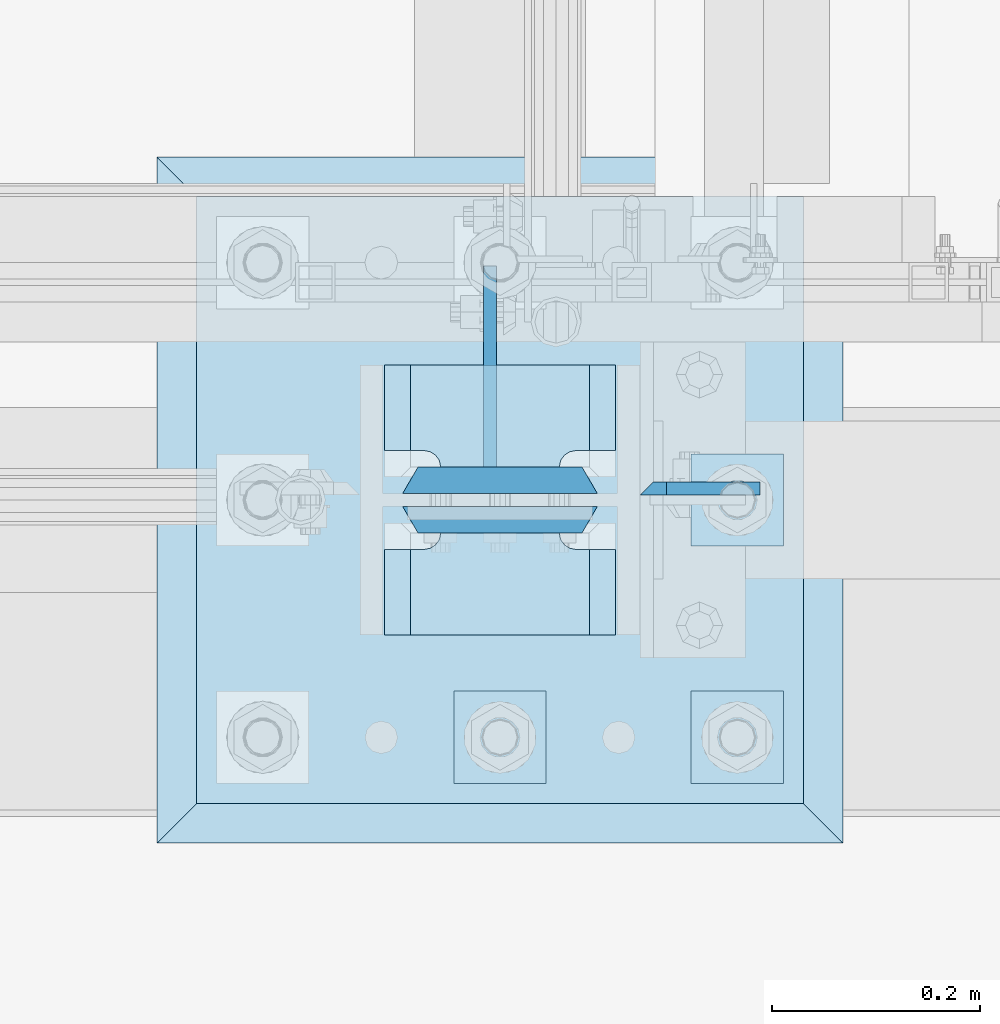
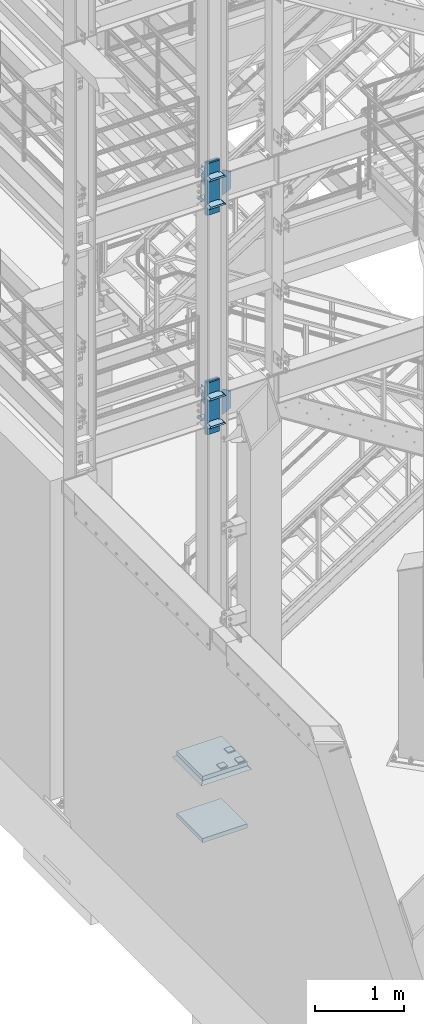
# One storey, part 1436 of 1876: 22 plates, 3 elements without a shape of their own.
"""IFC2X3 building model written with IfcOpenShell, lengths in millimetres."""

import ifcopenshell
import ifcopenshell.guid

model = None  # the IFC model being written
_history = None  # IfcOwnerHistory: only IFC2X3 demands one
_inside = {}  # id of a spatial element -> (the spatial element, [elements in it])
_under = {}  # id of a project, library or spatial element -> (it, [spatial elements below it])
_declared = {}  # id of a project -> (the project, [libraries it declares])
_typed = {}  # id of a type object -> (the type object, [elements of that type])
_made_of = {}  # id of a material, layer set ... -> (it, [elements and type objects made of it])


def new_model(schema):
    """Start an empty IFC model of exactly this schema.

    Asked for "IFC4X3", IfcOpenShell would pick the latest addendum, in which some entities
    have other attributes; the version numbers below select the first issue.
    IFC2X3 requires an IfcOwnerHistory on every rooted entity: one is made here for all.
    """
    global model, _history
    if schema == "IFC4X3":
        model = ifcopenshell.file(schema_version=(4, 3, 0, 0))
    else:
        model = ifcopenshell.file(schema=schema)
    _inside.clear()
    _under.clear()
    _declared.clear()
    _typed.clear()
    _made_of.clear()
    _history = None
    if model.schema == "IFC2X3":
        org = make("IfcOrganization", Name="unknown")
        user = make(
            "IfcPersonAndOrganization",
            ThePerson=make("IfcPerson", FamilyName="unknown"),
            TheOrganization=org,
        )
        app = make(
            "IfcApplication",
            ApplicationDeveloper=org,
            Version="unknown",
            ApplicationFullName="unknown",
            ApplicationIdentifier="unknown",
        )
        _history = make(
            "IfcOwnerHistory",
            OwningUser=user,
            OwningApplication=app,
            ChangeAction="ADDED",
            CreationDate=0,
        )
    return model


def make(cls, **values):
    """One entity of the class cls with the attributes given. An attribute that is None is left unset."""
    return model.create_entity(
        cls, **{name: value for name, value in values.items() if value is not None}
    )


def rooted(cls, **values):
    """An entity with a GlobalId (a new one), such as an element, a storey or a relation."""
    return make(cls, GlobalId=ifcopenshell.guid.new(), OwnerHistory=_history, **values)


def si_unit(unit_type, name, prefix=None):
    """IfcSIUnit, for example si_unit("LENGTHUNIT", "METRE", prefix="MILLI")."""
    return make("IfcSIUnit", UnitType=unit_type, Prefix=prefix, Name=name)


def assignment(units):
    """IfcUnitAssignment: the units of a project."""
    return None if units is None else make("IfcUnitAssignment", Units=units)


def point(xyz):
    """IfcCartesianPoint."""
    return None if xyz is None else make("IfcCartesianPoint", Coordinates=xyz)


def direction(xyz):
    """IfcDirection."""
    return None if xyz is None else make("IfcDirection", DirectionRatios=xyz)


def frame(location, z_axis=None, x_axis=None):
    """IfcAxis2Placement3D, a coordinate frame: its origin and axes. An axis left out is left unset."""
    return make(
        "IfcAxis2Placement3D",
        Location=point(location),
        Axis=direction(z_axis),
        RefDirection=direction(x_axis),
    )


def origin_with_axes():
    """The frame at (0, 0, 0) with the z axis (0, 0, 1) and the x axis (1, 0, 0) written out."""
    return frame((0.0, 0.0, 0.0), z_axis=(0.0, 0.0, 1.0), x_axis=(1.0, 0.0, 0.0))


def place(relative_to, where):
    """IfcLocalPlacement: puts the frame where relative to a parent placement (None: the world)."""
    return make(
        "IfcLocalPlacement", PlacementRelTo=relative_to, RelativePlacement=where
    )


def context(
    kind, dimensions, precision=None, world=None, true_north=None, identifier=None
):
    """IfcGeometricRepresentationContext, for example the 3D "Model" context."""
    return make(
        "IfcGeometricRepresentationContext",
        ContextIdentifier=identifier,
        ContextType=kind,
        CoordinateSpaceDimension=dimensions,
        Precision=precision,
        WorldCoordinateSystem=world,
        TrueNorth=true_north,
    )


def subcontext(parent, identifier, kind, view, scale=None):
    """IfcGeometricRepresentationSubContext, for example "Body" below "Model"."""
    return make(
        "IfcGeometricRepresentationSubContext",
        ContextIdentifier=identifier,
        ContextType=kind,
        ParentContext=parent,
        TargetScale=scale,
        TargetView=view,
    )


def project(units=None, contexts=None):
    """IfcProject with its units and contexts."""
    return rooted(
        "IfcProject",
        Name="project",
        RepresentationContexts=contexts,
        UnitsInContext=assignment(units),
    )


def spatial(cls, under=None, at=None, **own):
    """A site, building, storey or space (cls), placed at a placement, below another one or the project."""
    s = rooted(cls, ObjectPlacement=at, **own)
    if under is not None:
        _under.setdefault(under.id(), (under, []))[1].append(s)
    return s


def faces_of(points, faces, orient=None, outer=None):
    """IfcFace entities. A face is a list of loops; a loop is a list of indices into points, from 0.

    orient and outer hold one flag for each loop. By default every Orientation is true, the
    first loop of a face is its IfcFaceOuterBound and the others are IfcFaceBound.
    """
    made = []
    for i, loops in enumerate(faces):
        bounds = []
        for j, loop in enumerate(loops):
            is_outer = j == 0 if outer is None else outer[i][j]
            bounds.append(
                make(
                    "IfcFaceOuterBound" if is_outer else "IfcFaceBound",
                    Bound=make("IfcPolyLoop", Polygon=[points[k] for k in loop]),
                    Orientation=True if orient is None else orient[i][j],
                )
            )
        made.append(make("IfcFace", Bounds=bounds))
    return made


def faceted_brep(points, faces, orient=None, outer=None, voids=None):
    """IfcFacetedBrep: a solid bounded by flat faces; with voids (closed shells), ...WithVoids."""
    shared = [point(p) for p in points]
    hull = make("IfcClosedShell", CfsFaces=faces_of(shared, faces, orient, outer))
    if voids is None:
        return make("IfcFacetedBrep", Outer=hull)
    return make(
        "IfcFacetedBrepWithVoids",
        Outer=hull,
        Voids=[
            make(cls, CfsFaces=faces_of(shared, fs, o, b)) for cls, fs, o, b in voids
        ],
    )


def shape(context_of_items, identifier, shape_type, items):
    """IfcShapeRepresentation: the items that make up one representation, for example the "Body"."""
    return make(
        "IfcShapeRepresentation",
        ContextOfItems=context_of_items,
        RepresentationIdentifier=identifier,
        RepresentationType=shape_type,
        Items=items,
    )


def material(Name=None, Category=None):
    """IfcMaterial."""
    return make("IfcMaterial", Name=Name, Category=Category)


def made_of(thing, what):
    """Note that an element or type object is made of a material, layer set ...; save() writes the relation."""
    if what is not None:
        _made_of.setdefault(what.id(), (what, []))[1].append(thing)
    return thing


def type_object(cls, material=None, **own):
    """A type object (cls), such as IfcWallType, which elements share."""
    return made_of(rooted(cls, **own), material)


def element(
    cls,
    number,
    at=None,
    inside=None,
    cuts=None,
    type_object=None,
    material=None,
    context=None,
    identifier="Body",
    shape_type=None,
    held_by="IfcProductDefinitionShape",
    body=None,
    shapes=None,
    **own,
):
    """One element of the class cls, such as IfcWall. Its Tag is "e" and its number.

    at: its placement. inside: the storey or other place that contains it. cuts: it is an
    opening in that element (IfcRelVoidsElement). A single representation is given by context,
    identifier, shape_type and body (its items); several are given by shapes. held_by: the class
    of the entity that holds the representations. save() writes the other relations.
    """
    e = rooted(cls, Tag="e%d" % number, ObjectPlacement=at, **own)
    if body is not None:
        shapes = [shape(context, identifier, shape_type, body)]
    if shapes is not None:
        e.Representation = make(held_by, Representations=shapes)
    if inside is not None:
        _inside.setdefault(inside.id(), (inside, []))[1].append(e)
    if cuts is not None:
        rooted(
            "IfcRelVoidsElement", RelatingBuildingElement=cuts, RelatedOpeningElement=e
        )
    if type_object is not None:
        _typed.setdefault(type_object.id(), (type_object, []))[1].append(e)
    return made_of(e, material)


def aggregate(whole, parts):
    """IfcRelAggregates: a whole, such as a stair, and the parts it consists of."""
    return rooted("IfcRelAggregates", RelatingObject=whole, RelatedObjects=parts)


def save(model, path):
    """Write the relations noted so far, then the file.

    IfcRelAggregates (storeys below a building ...), IfcRelContainedInSpatialStructure (elements
    in a storey), IfcRelDefinesByType, IfcRelAssociatesMaterial and IfcRelDeclares: one each for
    every whole, place, type object, material and project.
    """
    for whole, parts in _under.values():
        aggregate(whole, parts)
    for where, things in _inside.values():
        rooted(
            "IfcRelContainedInSpatialStructure",
            RelatedElements=things,
            RelatingStructure=where,
        )
    for kind, things in _typed.values():
        rooted("IfcRelDefinesByType", RelatedObjects=things, RelatingType=kind)
    for what, things in _made_of.values():
        rooted("IfcRelAssociatesMaterial", RelatedObjects=things, RelatingMaterial=what)
    for by, libraries in _declared.values():
        rooted("IfcRelDeclares", RelatingContext=by, RelatedDefinitions=libraries)
    model.write(path)


model = new_model("IFC2X3")

# Units and contexts
model_context = context("Model", 3, precision=1e-05, world=origin_with_axes())
body_context = subcontext(model_context, "Body", "Model", "MODEL_VIEW")
ifc_project = project(units=[si_unit("LENGTHUNIT", "METRE", prefix="MILLI"), si_unit("AREAUNIT", "SQUARE_METRE"), si_unit("VOLUMEUNIT", "CUBIC_METRE"), si_unit("MASSUNIT", "GRAM", prefix="KILO"), si_unit("TIMEUNIT", "SECOND"), si_unit("PLANEANGLEUNIT", "RADIAN"), si_unit("SOLIDANGLEUNIT", "STERADIAN"), si_unit("THERMODYNAMICTEMPERATUREUNIT", "DEGREE_CELSIUS"), si_unit("LUMINOUSINTENSITYUNIT", "LUMEN")], contexts=[model_context])

# Site, building, storey
site_placement = place(None, origin_with_axes())
site = spatial("IfcSite", under=ifc_project, at=site_placement, CompositionType="ELEMENT")
building_placement = place(site_placement, origin_with_axes())
building = spatial("IfcBuilding", under=site, at=building_placement, Name="Undefined", CompositionType="ELEMENT")
storey_placement = place(building_placement, origin_with_axes())
storey = spatial("IfcBuildingStorey", under=building, at=storey_placement, Name="Undefined", CompositionType="ELEMENT", Elevation=0.0)

# Assembly, plates
assembly_1_placement = place(storey_placement, origin_with_axes())
assembly_1 = element("IfcElementAssembly", 1, at=assembly_1_placement, inside=storey, Name="COLUMN", AssemblyPlace="NOTDEFINED", PredefinedType="RIGID_FRAME")
ifc_material_1 = material(Name="STEEL/A572-50")
plate_type_1 = type_object("IfcPlateType", PredefinedType="NOTDEFINED")
plate_1_placement = place(assembly_1_placement, frame((1862.1375, -7100.88799991608, 8116.8875), z_axis=(1.0, 0.0, 0.0), x_axis=(0.0, 0.0, -1.0)))
plate_1 = element("IfcPlate", 2, at=plate_1_placement, type_object=plate_type_1, material=ifc_material_1, Name="PLATE", context=body_context, shape_type="Brep", body=[
    faceted_brep([(0.0, -6.35000000000036, 0.0), (-1.06936913171421e-12, 6.34999999999945, 12.699999332428), (336.549987792969, 6.35000000000036, 12.7), (336.549987792969, -6.35000000000036, 0.0), (336.550000000001, -6.35000000000036, 25.4000000000005), (336.549987792969, 6.35000000000036, 25.4000000000005), (284.53616791736, 6.35000000000036, 115.490600585938), (284.53616791736, -6.35000000000036, 115.490600307004), (52.0138320922852, -6.35000000000036, 115.490599060059), (52.0138320922852, 6.35000000000036, 115.490600585938), (0.0, 6.35000000000036, 25.4000000000005), (0.0, -6.35000000000036, 25.4000000000005)], [[[0, 1, 2, 3]], [[4, 5, 6, 7]], [[8, 9, 10, 11]], [[11, 10, 1, 0]], [[8, 11, 0, 3, 4, 7]], [[9, 8, 7, 6]], [[10, 9, 6, 5, 2, 1]], [[5, 4, 3, 2]]]),
])
plate_2_placement = place(assembly_1_placement, frame((1862.1375, -7100.88799991608, 5094.2875), z_axis=(1.0, 0.0, 0.0), x_axis=(0.0, 0.0, -1.0)))
plate_2 = element("IfcPlate", 3, at=plate_2_placement, type_object=plate_type_1, material=ifc_material_1, Name="PLATE", context=body_context, shape_type="Brep", body=[
    faceted_brep([(336.549987792969, 6.35049991607593, 12.6999998092654), (336.549987792969, -6.35000000000036, 0.0), (0.0, -6.35000000000036, 0.0), (-1.06936913171421e-12, 6.34999999999945, 12.699999332428), (52.0138320922852, -6.35000000000036, 115.490599060059), (52.0138320922852, 6.35000000000036, 115.490600585938), (0.0, 6.35000000000036, 25.4000000000005), (0.0, -6.35000000000036, 25.4000000000005), (284.53616791736, -6.35000000000036, 115.490600307004), (284.53616791736, 6.35000000000036, 115.490600585938), (336.550000000001, -6.35000000000036, 25.4000000000005), (336.549987792969, 6.35000000000036, 25.4000000000005)], [[[0, 1, 2, 3]], [[4, 5, 6, 7]], [[5, 4, 8, 9]], [[10, 11, 9, 8]], [[6, 5, 9, 11, 0, 3]], [[7, 6, 3, 2]], [[4, 7, 2, 1, 10, 8]], [[11, 10, 1, 0]]]),
])
ifc_material_2 = material(Name="STEEL/A572-GR.50")
plate_type_2 = type_object("IfcPlateType", PredefinedType="NOTDEFINED")
plate_3_placement = place(assembly_1_placement, frame((1838.325, -7143.75, 7756.52499389648), z_axis=(-1.0, 0.0, 0.0), x_axis=(0.0, -1.0, 0.0)))
plate_3 = element("IfcPlate", 4, at=plate_3_placement, type_object=plate_type_2, material=ifc_material_2, Name="PLATE", context=body_context, shape_type="Brep", body=[
    faceted_brep([(98.4250030517578, -12.7000000000007, 222.25), (98.4250030517578, 12.7000000000007, 197.150000002177), (15.875, 12.7000000000007, 197.150000002177), (15.875, -12.7000000000007, 222.25), (14.6665875786157, -12.7000000000007, 178.074902037082), (15.875, -12.7000000000007, 184.150001525879), (15.875, 12.7000000000007, 184.150001525879), (14.6665875786157, 12.7000000000007, 178.074902037082), (11.2253201513358, -12.7000000000007, 172.924681374541), (11.2253201513358, 12.7000000000007, 172.924681374541), (6.07509948879488, -12.7000000000007, 169.483413947261), (6.07509948879488, 12.7000000000007, 169.483413947261), (0.0, -12.7000000000007, 168.275001525879), (0.0, 12.7000000000007, 168.275001525879), (0.0, -12.7000000000007, 53.9749984741211), (0.0, 12.7000000000007, 53.9749984741211), (6.07509948879579, -12.7000000000007, 52.7665860527377), (6.07509948879579, 12.7000000000007, 52.7665860527377), (11.2253201513367, -12.7000000000007, 49.3253186254576), (11.2253201513367, 12.7000000000007, 49.3253186254576), (14.6665875786166, -12.7000000000007, 44.1750979629169), (14.6665875786166, 12.7000000000007, 44.1750979629169), (15.875, -12.7000000000007, 38.0999984741211), (15.875, 12.7000000000007, 38.0999984741211), (15.875, 12.7000000000007, 25.0999999978233), (15.875, -12.7000000000007, 0.0), (98.4250030517578, 12.7000000000007, 25.0999999978233), (98.4250030517578, -12.7000000000007, 0.0)], [[[0, 1, 2, 3]], [[4, 5, 6, 7]], [[8, 4, 7, 9]], [[10, 8, 9, 11]], [[12, 10, 11, 13]], [[14, 12, 13, 15]], [[16, 14, 15, 17]], [[18, 16, 17, 19]], [[20, 18, 19, 21]], [[22, 20, 21, 23]], [[22, 23, 24, 25]], [[26, 27, 25, 24]], [[5, 4, 8, 10, 12, 14, 16, 18, 20, 22, 25, 27, 0, 3]], [[6, 5, 3, 2]], [[26, 24, 23, 21, 19, 17, 15, 13, 11, 9, 7, 6, 2, 1]], [[27, 26, 1, 0]]]),
])
plate_4_placement = place(assembly_1_placement, frame((1838.325, -7143.75, 8140.7), z_axis=(-1.0, 0.0, 0.0), x_axis=(0.0, -1.0, 0.0)))
plate_4 = element("IfcPlate", 5, at=plate_4_placement, type_object=plate_type_2, material=ifc_material_2, Name="PLATE", context=body_context, shape_type="Brep", body=[
    faceted_brep([(98.4250030517578, -12.7000000000007, 222.25), (98.4250030517578, 12.7000000000007, 197.150000002177), (15.875, 12.7000000000007, 197.150000002177), (15.875, -12.7000000000007, 222.25), (14.6665875786157, -12.7000000000007, 178.074902037082), (15.875, -12.7000000000007, 184.150001525879), (15.875, 12.7000000000007, 184.150001525879), (14.6665875786157, 12.7000000000007, 178.074902037082), (11.2253201513358, -12.7000000000007, 172.924681374541), (11.2253201513358, 12.7000000000007, 172.924681374541), (6.07509948879488, -12.7000000000007, 169.483413947261), (6.07509948879488, 12.7000000000007, 169.483413947261), (0.0, -12.7000000000007, 168.275001525879), (0.0, 12.7000000000007, 168.275001525879), (0.0, -12.7000000000007, 53.9749984741211), (0.0, 12.7000000000007, 53.9749984741211), (6.07509948879579, -12.7000000000007, 52.7665860527377), (6.07509948879579, 12.7000000000007, 52.7665860527377), (11.2253201513367, -12.7000000000007, 49.3253186254576), (11.2253201513367, 12.7000000000007, 49.3253186254576), (14.6665875786166, -12.7000000000007, 44.1750979629169), (14.6665875786166, 12.7000000000007, 44.1750979629169), (15.875, -12.7000000000007, 38.0999984741211), (15.875, 12.7000000000007, 38.0999984741211), (15.875, 12.7000000000007, 25.0999999978233), (15.875, -12.7000000000007, 0.0), (98.4250030517578, 12.7000000000007, 25.0999999978233), (98.4250030517578, -12.7000000000007, 0.0)], [[[0, 1, 2, 3]], [[4, 5, 6, 7]], [[8, 4, 7, 9]], [[10, 8, 9, 11]], [[12, 10, 11, 13]], [[14, 12, 13, 15]], [[16, 14, 15, 17]], [[18, 16, 17, 19]], [[20, 18, 19, 21]], [[22, 20, 21, 23]], [[22, 23, 24, 25]], [[26, 27, 25, 24]], [[5, 4, 8, 10, 12, 14, 16, 18, 20, 22, 25, 27, 0, 3]], [[6, 5, 3, 2]], [[26, 24, 23, 21, 19, 17, 15, 13, 11, 9, 7, 6, 2, 1]], [[27, 26, 1, 0]]]),
])
plate_5_placement = place(assembly_1_placement, frame((1838.325, -6981.825, 7756.52499389648), z_axis=(-1.0, 0.0, 0.0), x_axis=(0.0, -1.0, 0.0)))
plate_5 = element("IfcPlate", 6, at=plate_5_placement, type_object=plate_type_2, material=ifc_material_2, Name="PLATE", context=body_context, shape_type="Brep", body=[
    faceted_brep([(82.5500030517578, -12.7000000000007, 222.25), (82.5500030517578, 12.7000000000007, 197.150000002177), (0.0, 12.7000000000007, 197.150000002177), (0.0, -12.7000000000007, 222.25), (82.5500030517578, 12.7000000000007, 25.0999999978233), (82.5500030517578, -12.7000000000007, 0.0), (0.0, -12.6999999999998, 0.0), (0.0, 12.7000000000007, 25.0999999978233), (82.5500030517578, 12.7000000000007, 38.0999984741211), (82.5500030517578, -12.7000000000007, 38.0999984741211), (83.7584154731412, -12.7000000000007, 44.1750979629169), (83.7584154731412, 12.7000000000007, 44.1750979629169), (87.1996829004211, -12.7000000000007, 49.3253186254576), (87.1996829004211, 12.7000000000007, 49.3253186254576), (92.349903562962, -12.7000000000007, 52.7665860527377), (92.349903562962, 12.7000000000007, 52.7665860527377), (98.4250030517578, -12.7000000000007, 53.9749984741211), (98.4250030517578, 12.7000000000007, 53.9749984741211), (98.4250030517578, -12.7000000000007, 168.275001525879), (98.4250030517578, 12.7000000000007, 168.275001525879), (92.349903562962, -12.7000000000007, 169.483413947262), (92.349903562962, 12.7000000000007, 169.483413947262), (87.1996829004211, -12.7000000000007, 172.924681374543), (87.1996829004211, 12.7000000000007, 172.924681374543), (83.7584154731412, -12.7000000000007, 178.074902037083), (83.7584154731412, 12.7000000000007, 178.074902037083), (82.5500030517578, -12.7000000000007, 184.150001525879), (82.5500030517578, 12.7000000000007, 184.150001525879)], [[[0, 1, 2, 3]], [[4, 5, 6, 7]], [[8, 9, 5, 4]], [[10, 9, 8, 11]], [[12, 10, 11, 13]], [[14, 12, 13, 15]], [[16, 14, 15, 17]], [[18, 16, 17, 19]], [[20, 18, 19, 21]], [[22, 20, 21, 23]], [[24, 22, 23, 25]], [[26, 24, 25, 27]], [[6, 5, 9, 10, 12, 14, 16, 18, 20, 22, 24, 26, 0, 3]], [[7, 6, 3, 2]], [[27, 25, 23, 21, 19, 17, 15, 13, 11, 8, 4, 7, 2, 1]], [[26, 27, 1, 0]]]),
])
plate_6_placement = place(assembly_1_placement, frame((1838.325, -6981.825, 8140.7), z_axis=(-1.0, 0.0, 0.0), x_axis=(0.0, -1.0, 0.0)))
plate_6 = element("IfcPlate", 7, at=plate_6_placement, type_object=plate_type_2, material=ifc_material_2, Name="PLATE", context=body_context, shape_type="Brep", body=[
    faceted_brep([(82.5500030517578, -12.7000000000007, 222.25), (82.5500030517578, 12.7000000000007, 197.150000002177), (0.0, 12.7000000000007, 197.150000002177), (0.0, -12.7000000000007, 222.25), (82.5500030517578, 12.7000000000007, 25.0999999978233), (82.5500030517578, -12.7000000000007, 0.0), (0.0, -12.6999999999998, 0.0), (0.0, 12.7000000000007, 25.0999999978233), (82.5500030517578, 12.7000000000007, 38.0999984741211), (82.5500030517578, -12.7000000000007, 38.0999984741211), (83.7584154731412, -12.7000000000007, 44.1750979629169), (83.7584154731412, 12.7000000000007, 44.1750979629169), (87.1996829004211, -12.7000000000007, 49.3253186254576), (87.1996829004211, 12.7000000000007, 49.3253186254576), (92.349903562962, -12.7000000000007, 52.7665860527377), (92.349903562962, 12.7000000000007, 52.7665860527377), (98.4250030517578, -12.7000000000007, 53.9749984741211), (98.4250030517578, 12.7000000000007, 53.9749984741211), (98.4250030517578, -12.7000000000007, 168.275001525879), (98.4250030517578, 12.7000000000007, 168.275001525879), (92.349903562962, -12.7000000000007, 169.483413947262), (92.349903562962, 12.7000000000007, 169.483413947262), (87.1996829004211, -12.7000000000007, 172.924681374543), (87.1996829004211, 12.7000000000007, 172.924681374543), (83.7584154731412, -12.7000000000007, 178.074902037083), (83.7584154731412, 12.7000000000007, 178.074902037083), (82.5500030517578, -12.7000000000007, 184.150001525879), (82.5500030517578, 12.7000000000007, 184.150001525879)], [[[0, 1, 2, 3]], [[4, 5, 6, 7]], [[8, 9, 5, 4]], [[10, 9, 8, 11]], [[12, 10, 11, 13]], [[14, 12, 13, 15]], [[16, 14, 15, 17]], [[18, 16, 17, 19]], [[20, 18, 19, 21]], [[22, 20, 21, 23]], [[24, 22, 23, 25]], [[26, 24, 25, 27]], [[6, 5, 9, 10, 12, 14, 16, 18, 20, 22, 24, 26, 0, 3]], [[7, 6, 3, 2]], [[27, 25, 23, 21, 19, 17, 15, 13, 11, 8, 4, 7, 2, 1]], [[26, 27, 1, 0]]]),
])
plate_7_placement = place(assembly_1_placement, frame((1838.325, -7143.75, 4733.92499389648), z_axis=(-1.0, 0.0, 0.0), x_axis=(0.0, -1.0, 0.0)))
plate_7 = element("IfcPlate", 8, at=plate_7_placement, type_object=plate_type_2, material=ifc_material_2, Name="PLATE", context=body_context, shape_type="Brep", body=[
    faceted_brep([(98.4250030517578, -12.7000000000007, 222.25), (98.4250030517578, 12.7000000000007, 197.150000002177), (15.875, 12.7000000000007, 197.150000002177), (15.875, -12.7000000000007, 222.25), (14.6665875786157, -12.7000000000007, 178.074902037082), (15.875, -12.7000000000007, 184.150001525879), (15.875, 12.7000000000007, 184.150001525879), (14.6665875786157, 12.7000000000007, 178.074902037082), (11.2253201513358, -12.7000000000007, 172.924681374541), (11.2253201513358, 12.7000000000007, 172.924681374541), (6.07509948879488, -12.7000000000007, 169.483413947261), (6.07509948879488, 12.7000000000007, 169.483413947261), (0.0, -12.7000000000007, 168.275001525879), (0.0, 12.7000000000007, 168.275001525879), (0.0, -12.7000000000007, 53.9749984741211), (0.0, 12.7000000000007, 53.9749984741211), (6.07509948879579, -12.7000000000007, 52.7665860527377), (6.07509948879579, 12.7000000000007, 52.7665860527377), (11.2253201513367, -12.7000000000007, 49.3253186254576), (11.2253201513367, 12.7000000000007, 49.3253186254576), (14.6665875786166, -12.7000000000007, 44.1750979629169), (14.6665875786166, 12.7000000000007, 44.1750979629169), (15.875, -12.7000000000007, 38.0999984741211), (15.875, 12.7000000000007, 38.0999984741211), (15.875, 12.7000000000007, 25.0999999978233), (15.875, -12.7000000000007, 0.0), (98.4250030517578, 12.7000000000007, 25.0999999978233), (98.4250030517578, -12.7000000000007, 0.0)], [[[0, 1, 2, 3]], [[4, 5, 6, 7]], [[8, 4, 7, 9]], [[10, 8, 9, 11]], [[12, 10, 11, 13]], [[14, 12, 13, 15]], [[16, 14, 15, 17]], [[18, 16, 17, 19]], [[20, 18, 19, 21]], [[22, 20, 21, 23]], [[22, 23, 24, 25]], [[26, 27, 25, 24]], [[5, 4, 8, 10, 12, 14, 16, 18, 20, 22, 25, 27, 0, 3]], [[6, 5, 3, 2]], [[26, 24, 23, 21, 19, 17, 15, 13, 11, 9, 7, 6, 2, 1]], [[27, 26, 1, 0]]]),
])
plate_8_placement = place(assembly_1_placement, frame((1838.325, -7143.75, 5118.1), z_axis=(-1.0, 0.0, 0.0), x_axis=(0.0, -1.0, 0.0)))
plate_8 = element("IfcPlate", 9, at=plate_8_placement, type_object=plate_type_2, material=ifc_material_2, Name="PLATE", context=body_context, shape_type="Brep", body=[
    faceted_brep([(98.4250030517578, -12.7000000000007, 222.25), (98.4250030517578, 12.7000000000007, 197.150000002177), (15.875, 12.7000000000007, 197.150000002177), (15.875, -12.7000000000007, 222.25), (14.6665875786157, -12.7000000000007, 178.074902037082), (15.875, -12.7000000000007, 184.150001525879), (15.875, 12.7000000000007, 184.150001525879), (14.6665875786157, 12.7000000000007, 178.074902037082), (11.2253201513358, -12.7000000000007, 172.924681374541), (11.2253201513358, 12.7000000000007, 172.924681374541), (6.07509948879488, -12.7000000000007, 169.483413947261), (6.07509948879488, 12.7000000000007, 169.483413947261), (0.0, -12.7000000000007, 168.275001525879), (0.0, 12.7000000000007, 168.275001525879), (0.0, -12.7000000000007, 53.9749984741211), (0.0, 12.7000000000007, 53.9749984741211), (6.07509948879579, -12.7000000000007, 52.7665860527377), (6.07509948879579, 12.7000000000007, 52.7665860527377), (11.2253201513367, -12.7000000000007, 49.3253186254576), (11.2253201513367, 12.7000000000007, 49.3253186254576), (14.6665875786166, -12.7000000000007, 44.1750979629169), (14.6665875786166, 12.7000000000007, 44.1750979629169), (15.875, -12.7000000000007, 38.0999984741211), (15.875, 12.7000000000007, 38.0999984741211), (15.875, 12.7000000000007, 25.0999999978233), (15.875, -12.7000000000007, 0.0), (98.4250030517578, 12.7000000000007, 25.0999999978233), (98.4250030517578, -12.7000000000007, 0.0)], [[[0, 1, 2, 3]], [[4, 5, 6, 7]], [[8, 4, 7, 9]], [[10, 8, 9, 11]], [[12, 10, 11, 13]], [[14, 12, 13, 15]], [[16, 14, 15, 17]], [[18, 16, 17, 19]], [[20, 18, 19, 21]], [[22, 20, 21, 23]], [[22, 23, 24, 25]], [[26, 27, 25, 24]], [[5, 4, 8, 10, 12, 14, 16, 18, 20, 22, 25, 27, 0, 3]], [[6, 5, 3, 2]], [[26, 24, 23, 21, 19, 17, 15, 13, 11, 9, 7, 6, 2, 1]], [[27, 26, 1, 0]]]),
])
plate_9_placement = place(assembly_1_placement, frame((1838.325, -6981.825, 4733.92499389648), z_axis=(-1.0, 0.0, 0.0), x_axis=(0.0, -1.0, 0.0)))
plate_9 = element("IfcPlate", 10, at=plate_9_placement, type_object=plate_type_2, material=ifc_material_2, Name="PLATE", context=body_context, shape_type="Brep", body=[
    faceted_brep([(82.5500030517578, -12.7000000000007, 222.25), (82.5500030517578, 12.7000000000007, 197.150000002177), (0.0, 12.7000000000007, 197.150000002177), (0.0, -12.7000000000007, 222.25), (82.5500030517578, 12.7000000000007, 25.0999999978233), (82.5500030517578, -12.7000000000007, 0.0), (0.0, -12.6999999999998, 0.0), (0.0, 12.7000000000007, 25.0999999978233), (82.5500030517578, 12.7000000000007, 38.0999984741211), (82.5500030517578, -12.7000000000007, 38.0999984741211), (83.7584154731412, -12.7000000000007, 44.1750979629169), (83.7584154731412, 12.7000000000007, 44.1750979629169), (87.1996829004211, -12.7000000000007, 49.3253186254576), (87.1996829004211, 12.7000000000007, 49.3253186254576), (92.349903562962, -12.7000000000007, 52.7665860527377), (92.349903562962, 12.7000000000007, 52.7665860527377), (98.4250030517578, -12.7000000000007, 53.9749984741211), (98.4250030517578, 12.7000000000007, 53.9749984741211), (98.4250030517578, -12.7000000000007, 168.275001525879), (98.4250030517578, 12.7000000000007, 168.275001525879), (92.349903562962, -12.7000000000007, 169.483413947262), (92.349903562962, 12.7000000000007, 169.483413947262), (87.1996829004211, -12.7000000000007, 172.924681374543), (87.1996829004211, 12.7000000000007, 172.924681374543), (83.7584154731412, -12.7000000000007, 178.074902037083), (83.7584154731412, 12.7000000000007, 178.074902037083), (82.5500030517578, -12.7000000000007, 184.150001525879), (82.5500030517578, 12.7000000000007, 184.150001525879)], [[[0, 1, 2, 3]], [[4, 5, 6, 7]], [[8, 9, 5, 4]], [[10, 9, 8, 11]], [[12, 10, 11, 13]], [[14, 12, 13, 15]], [[16, 14, 15, 17]], [[18, 16, 17, 19]], [[20, 18, 19, 21]], [[22, 20, 21, 23]], [[24, 22, 23, 25]], [[26, 24, 25, 27]], [[6, 5, 9, 10, 12, 14, 16, 18, 20, 22, 24, 26, 0, 3]], [[7, 6, 3, 2]], [[27, 25, 23, 21, 19, 17, 15, 13, 11, 8, 4, 7, 2, 1]], [[26, 27, 1, 0]]]),
])
plate_10_placement = place(assembly_1_placement, frame((1838.325, -6981.825, 5118.1), z_axis=(-1.0, 0.0, 0.0), x_axis=(0.0, -1.0, 0.0)))
plate_10 = element("IfcPlate", 11, at=plate_10_placement, type_object=plate_type_2, material=ifc_material_2, Name="PLATE", context=body_context, shape_type="Brep", body=[
    faceted_brep([(82.5500030517578, -12.7000000000007, 222.25), (82.5500030517578, 12.7000000000007, 197.150000002177), (0.0, 12.7000000000007, 197.150000002177), (0.0, -12.7000000000007, 222.25), (82.5500030517578, 12.7000000000007, 25.0999999978233), (82.5500030517578, -12.7000000000007, 0.0), (0.0, -12.6999999999998, 0.0), (0.0, 12.7000000000007, 25.0999999978233), (82.5500030517578, 12.7000000000007, 38.0999984741211), (82.5500030517578, -12.7000000000007, 38.0999984741211), (83.7584154731412, -12.7000000000007, 44.1750979629169), (83.7584154731412, 12.7000000000007, 44.1750979629169), (87.1996829004211, -12.7000000000007, 49.3253186254576), (87.1996829004211, 12.7000000000007, 49.3253186254576), (92.349903562962, -12.7000000000007, 52.7665860527377), (92.349903562962, 12.7000000000007, 52.7665860527377), (98.4250030517578, -12.7000000000007, 53.9749984741211), (98.4250030517578, 12.7000000000007, 53.9749984741211), (98.4250030517578, -12.7000000000007, 168.275001525879), (98.4250030517578, 12.7000000000007, 168.275001525879), (92.349903562962, -12.7000000000007, 169.483413947262), (92.349903562962, 12.7000000000007, 169.483413947262), (87.1996829004211, -12.7000000000007, 172.924681374543), (87.1996829004211, 12.7000000000007, 172.924681374543), (83.7584154731412, -12.7000000000007, 178.074902037083), (83.7584154731412, 12.7000000000007, 178.074902037083), (82.5500030517578, -12.7000000000007, 184.150001525879), (82.5500030517578, 12.7000000000007, 184.150001525879)], [[[0, 1, 2, 3]], [[4, 5, 6, 7]], [[8, 9, 5, 4]], [[10, 9, 8, 11]], [[12, 10, 11, 13]], [[14, 12, 13, 15]], [[16, 14, 15, 17]], [[18, 16, 17, 19]], [[20, 18, 19, 21]], [[22, 20, 21, 23]], [[24, 22, 23, 25]], [[26, 24, 25, 27]], [[6, 5, 9, 10, 12, 14, 16, 18, 20, 22, 24, 26, 0, 3]], [[7, 6, 3, 2]], [[27, 25, 23, 21, 19, 17, 15, 13, 11, 8, 4, 7, 2, 1]], [[26, 27, 1, 0]]]),
])
plate_type_3 = type_object("IfcPlateType", PredefinedType="NOTDEFINED")
plate_11_placement = place(assembly_1_placement, frame((1633.5375, -7131.05, 8305.8), z_axis=(1.0, 0.0, 0.0), x_axis=(0.0, 0.0, -1.0)))
plate_11 = element("IfcPlate", 12, at=plate_11_placement, type_object=plate_type_3, material=ifc_material_2, Name="PLATE", context=body_context, shape_type="Brep", body=[
    faceted_brep([(0.0, -12.6999999999998, 172.660303166218), (714.375, -12.6999999999998, 172.660303166232), (714.375, 12.6999999999998, 187.324996948242), (0.0, 12.6999999999998, 187.324996948242), (714.375, -12.6999999999998, 14.6646968337647), (714.375, 12.6999999999998, 0.0), (0.0, 12.6999999999998, 0.0), (0.0, -12.6999999999998, 14.6646968337648)], [[[0, 1, 2, 3]], [[2, 1, 4, 5]], [[3, 2, 5, 6]], [[0, 3, 6, 7]], [[1, 0, 7, 4]], [[6, 5, 4, 7]]]),
])
plate_12_placement = place(assembly_1_placement, frame((1633.5375, -7092.95, 8305.8), z_axis=(1.0, 0.0, 0.0), x_axis=(0.0, 0.0, -1.0)))
plate_12 = element("IfcPlate", 13, at=plate_12_placement, type_object=plate_type_3, material=ifc_material_2, Name="PLATE", context=body_context, shape_type="Brep", body=[
    faceted_brep([(0.0, 12.6999999999998, 172.66030316161), (0.0, -12.6999999999998, 187.324996948242), (714.375, -12.6999999999998, 187.324996948242), (714.375, 12.6999999999998, 172.660303161603), (714.375, 12.6999999999998, 14.6646968384017), (0.0, 12.6999999999998, 14.6646968383725), (0.0, -12.6999999999998, 0.0), (714.375, -12.6999999999998, 0.0)], [[[0, 1, 2, 3]], [[0, 3, 4, 5]], [[1, 0, 5, 6]], [[2, 1, 6, 7]], [[3, 2, 7, 4]], [[6, 5, 4, 7]]]),
])
plate_13_placement = place(assembly_1_placement, frame((1633.5375, -7131.05, 5283.2), z_axis=(1.0, 0.0, 0.0), x_axis=(0.0, 0.0, -1.0)))
plate_13 = element("IfcPlate", 14, at=plate_13_placement, type_object=plate_type_3, material=ifc_material_2, Name="PLATE", context=body_context, shape_type="Brep", body=[
    faceted_brep([(0.0, -12.6999999999998, 172.660303166218), (714.375, -12.6999999999998, 172.660303166232), (714.375, 12.6999999999998, 187.324996948242), (0.0, 12.6999999999998, 187.324996948242), (714.375, -12.6999999999998, 14.6646968337647), (714.375, 12.6999999999998, 0.0), (0.0, 12.6999999999998, 0.0), (0.0, -12.6999999999998, 14.6646968337648)], [[[0, 1, 2, 3]], [[2, 1, 4, 5]], [[3, 2, 5, 6]], [[0, 3, 6, 7]], [[1, 0, 7, 4]], [[6, 5, 4, 7]]]),
])
plate_14_placement = place(assembly_1_placement, frame((1633.5375, -7092.95, 5283.2), z_axis=(1.0, 0.0, 0.0), x_axis=(0.0, 0.0, -1.0)))
plate_14 = element("IfcPlate", 15, at=plate_14_placement, type_object=plate_type_3, material=ifc_material_2, Name="PLATE", context=body_context, shape_type="Brep", body=[
    faceted_brep([(0.0, 12.6999999999998, 172.66030316161), (0.0, -12.6999999999998, 187.324996948242), (714.375, -12.6999999999998, 187.324996948242), (714.375, 12.6999999999998, 172.660303161603), (714.375, 12.6999999999998, 14.6646968384017), (0.0, 12.6999999999998, 14.6646968383725), (0.0, -12.6999999999998, 0.0), (714.375, -12.6999999999998, 0.0)], [[[0, 1, 2, 3]], [[0, 3, 4, 5]], [[1, 0, 5, 6]], [[2, 1, 6, 7]], [[3, 2, 7, 4]], [[6, 5, 4, 7]]]),
])
plate_type_4 = type_object("IfcPlateType", PredefinedType="NOTDEFINED")
plate_15_placement = place(assembly_1_placement, frame((1717.67500004768, -7080.25, 8115.3), z_axis=(0.0, 1.0, 0.0), x_axis=(0.0, 0.0, -1.0)))
plate_15 = element("IfcPlate", 16, at=plate_15_placement, type_object=plate_type_4, material=ifc_material_1, Name="PLATE", context=body_context, shape_type="Brep", body=[
    faceted_brep([(0.0, -6.35000000000036, 0.0), (0.0, -6.34999999999991, 193.675003051758), (0.0, 6.34999999999991, 193.675003051758), (0.0, 6.35000000000036, 0.0), (228.600006103516, -6.34999999999991, 193.675003051758), (228.600006103516, 6.34999999999991, 193.675003051758), (228.600006103516, -6.34999999999854, 0.0), (228.600006103516, 6.34999999999854, 0.0)], [[[0, 1, 2, 3]], [[1, 4, 5, 2]], [[4, 6, 7, 5]], [[6, 0, 3, 7]], [[5, 7, 3, 2]], [[6, 4, 1, 0]]]),
])
plate_16_placement = place(assembly_1_placement, frame((1717.67500004768, -7080.25, 5092.7), z_axis=(0.0, 1.0, 0.0), x_axis=(0.0, 0.0, -1.0)))
plate_16 = element("IfcPlate", 17, at=plate_16_placement, type_object=plate_type_4, material=ifc_material_1, Name="PLATE", context=body_context, shape_type="Brep", body=[
    faceted_brep([(0.0, -6.35000000000036, 0.0), (0.0, -6.34999999999991, 193.675003051758), (0.0, 6.34999999999991, 193.675003051758), (0.0, 6.35000000000036, 0.0), (228.600006103516, -6.34999999999991, 193.675003051758), (228.600006103516, 6.34999999999991, 193.675003051758), (228.600006103516, -6.34999999999854, 0.0), (228.600006103516, 6.34999999999854, 0.0)], [[[0, 1, 2, 3]], [[1, 4, 5, 2]], [[4, 6, 7, 5]], [[6, 0, 3, 7]], [[5, 7, 3, 2]], [[6, 4, 1, 0]]]),
])

# Assembly, plate
assembly_2_placement = place(storey_placement, origin_with_axes())
assembly_2 = element("IfcElementAssembly", 18, at=assembly_2_placement, inside=storey, Name="TEMPLATE", AssemblyPlace="NOTDEFINED", PredefinedType="RIGID_FRAME")
plate_type_5 = type_object("IfcPlateType", PredefinedType="NOTDEFINED")
plate_17_placement = place(assembly_2_placement, frame((1435.1, -7404.1, -790.575), z_axis=(0.0, 1.0, 0.0), x_axis=(1.0, 0.0, 0.0)))
plate_17 = element("IfcPlate", 19, at=plate_17_placement, type_object=plate_type_5, material=ifc_material_1, Name="PLATE", context=body_context, shape_type="Brep", body=[
    faceted_brep([(0.0, -28.575, 0.0), (0.0, -28.575, 584.200012207031), (0.0, 28.575, 584.200012207031), (0.0, 28.575, 0.0), (584.200012207031, -28.575, 584.200012207031), (584.200012207031, 28.575, 584.200012207031), (584.200012207031, -28.575, 0.0), (584.200012207031, 28.575, 0.0)], [[[0, 1, 2, 3]], [[1, 4, 5, 2]], [[4, 6, 7, 5]], [[6, 0, 3, 7]], [[5, 7, 3, 2]], [[6, 4, 1, 0]]]),
])

# Plate
plate_18_placement = place(assembly_1_placement, frame((1435.1, -7404.1, 66.675), z_axis=(0.0, 1.0, 0.0), x_axis=(1.0, 0.0, 0.0)))
plate_18 = element("IfcPlate", 20, at=plate_18_placement, type_object=plate_type_5, material=ifc_material_2, Name="PLATE", context=body_context, shape_type="Brep", body=[
    faceted_brep([(0.0, -28.575, 0.0), (0.0, -28.575, 584.200012207031), (0.0, 28.575, 584.200012207031), (0.0, 28.575, 0.0), (584.200012207031, -28.575, 584.200012207031), (584.200012207031, 28.575, 584.200012207031), (584.200012207031, -28.575, 0.0), (584.200012207031, 28.575, 0.0)], [[[0, 1, 2, 3]], [[1, 4, 5, 2]], [[4, 6, 7, 5]], [[6, 0, 3, 7]], [[5, 7, 3, 2]], [[6, 4, 1, 0]]]),
])

aggregate(assembly_1, [plate_1, plate_3, plate_4, plate_5, plate_6, plate_11, plate_12, plate_15, plate_7, plate_8, plate_9, plate_10, plate_13, plate_14, plate_16, plate_2, plate_18])

ifc_material_3 = material(Name="STEEL/A36")
plate_type_6 = type_object("IfcPlateType", PredefinedType="NOTDEFINED")
plate_19_placement = place(assembly_2_placement, frame((1911.35, -7296.15, 103.1875), z_axis=(0.0, -1.0, 0.0), x_axis=(1.0, 0.0, 0.0)))
plate_19 = element("IfcPlate", 21, at=plate_19_placement, type_object=plate_type_6, material=ifc_material_3, Name="PLATE WASHER", context=body_context, shape_type="Brep", body=[
    faceted_brep([(0.0, -7.9375, 0.0), (0.0, -7.9375, 88.9000015258789), (0.0, 7.9375, 88.9000015258789), (0.0, 7.9375, 0.0), (88.9000015258789, -7.9375, 88.9000015258789), (88.9000015258789, 7.9375, 88.9000015258789), (88.9000015258789, -7.9375, 0.0), (88.9000015258789, 7.9375, 0.0)], [[[0, 1, 2, 3]], [[1, 4, 5, 2]], [[4, 6, 7, 5]], [[6, 0, 3, 7]], [[5, 7, 3, 2]], [[6, 4, 1, 0]]]),
])

plate_20_placement = place(assembly_2_placement, frame((1911.35, -7067.55, 103.1875), z_axis=(0.0, -1.0, 0.0), x_axis=(1.0, 0.0, 0.0)))
plate_20 = element("IfcPlate", 22, at=plate_20_placement, type_object=plate_type_6, material=ifc_material_3, Name="PLATE WASHER", context=body_context, shape_type="Brep", body=[
    faceted_brep([(0.0, -7.9375, 0.0), (0.0, -7.9375, 88.9000015258789), (0.0, 7.9375, 88.9000015258789), (0.0, 7.9375, 0.0), (88.9000015258789, -7.9375, 88.9000015258789), (88.9000015258789, 7.9375, 88.9000015258789), (88.9000015258789, -7.9375, 0.0), (88.9000015258789, 7.9375, 0.0)], [[[0, 1, 2, 3]], [[1, 4, 5, 2]], [[4, 6, 7, 5]], [[6, 0, 3, 7]], [[5, 7, 3, 2]], [[6, 4, 1, 0]]]),
])

plate_21_placement = place(assembly_2_placement, frame((1682.75, -7296.15, 103.1875), z_axis=(0.0, -1.0, 0.0), x_axis=(1.0, 0.0, 0.0)))
plate_21 = element("IfcPlate", 23, at=plate_21_placement, type_object=plate_type_6, material=ifc_material_3, Name="PLATE WASHER", context=body_context, shape_type="Brep", body=[
    faceted_brep([(0.0, -7.9375, 0.0), (0.0, -7.9375, 88.9000015258789), (0.0, 7.9375, 88.9000015258789), (0.0, 7.9375, 0.0), (88.9000015258789, -7.9375, 88.9000015258789), (88.9000015258789, 7.9375, 88.9000015258789), (88.9000015258789, -7.9375, 0.0), (88.9000015258789, 7.9375, 0.0)], [[[0, 1, 2, 3]], [[1, 4, 5, 2]], [[4, 6, 7, 5]], [[6, 0, 3, 7]], [[5, 7, 3, 2]], [[6, 4, 1, 0]]]),
])

aggregate(assembly_2, [plate_17, plate_19, plate_20, plate_21])

# Assembly, plate
assembly_3_placement = place(storey_placement, origin_with_axes())
assembly_3 = element("IfcElementAssembly", 24, at=assembly_3_placement, inside=storey, Name="GROUT", AssemblyPlace="NOTDEFINED", PredefinedType="REINFORCEMENT_UNIT")
ifc_material_4 = material(Name="CONCRETE/Concrete_Undefined")
plate_type_7 = type_object("IfcPlateType", PredefinedType="NOTDEFINED")
plate_22_placement = place(assembly_3_placement, frame((1397.0, -7442.2, 19.05), z_axis=(0.0, 1.0, 0.0), x_axis=(1.0, 0.0, 0.0)))
plate_22 = element("IfcPlate", 25, at=plate_22_placement, type_object=plate_type_7, material=ifc_material_4, Name="GROUT", context=body_context, shape_type="Brep", body=[
    faceted_brep([(38.0999999999849, -19.05, 622.299999999983), (0.0, 19.05, 660.400024414062), (-9.09494701772928e-13, 19.05, -1.81898940354586e-12), (38.1000000120275, -19.05, 38.1000000109725), (622.299999999984, -19.05, 38.1000000000167), (660.400024414062, 19.05, 0.0), (660.400024414062, 19.05, 660.400024414062), (622.299999999984, -19.05, 622.299999999983)], [[[0, 1, 2, 3]], [[4, 5, 6, 7]], [[4, 7, 0, 3]], [[5, 4, 3, 2]], [[6, 5, 2, 1]], [[7, 6, 1, 0]]]),
])
aggregate(assembly_3, [plate_22])

save(model, "model.ifc")
